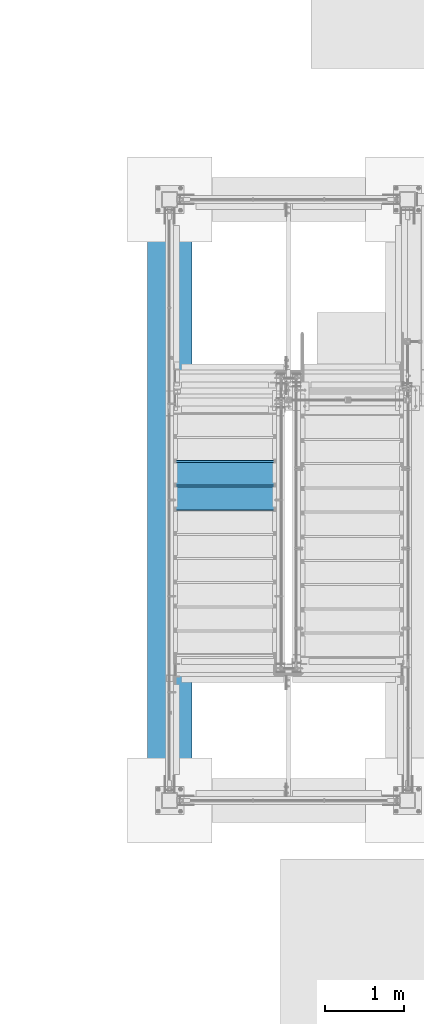
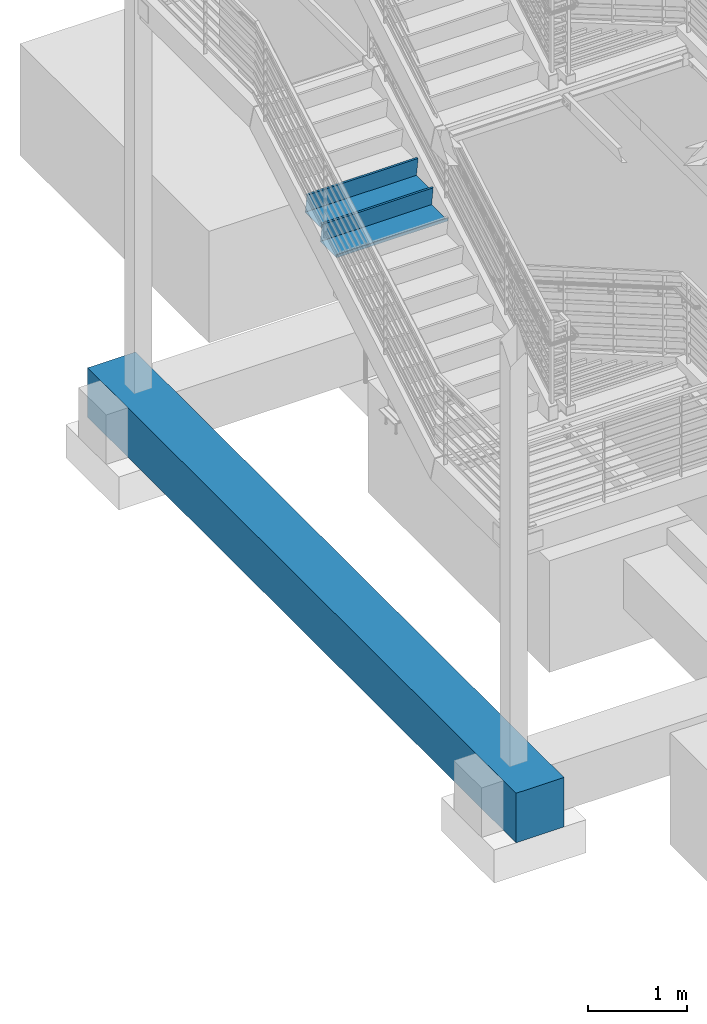
# One storey, part 757 of 1179: 3 beams, 2 elements without a shape of their own.
"""IFC2X3 building model written with IfcOpenShell, lengths in millimetres."""

from ifc_helpers import new_model, si_unit, frame, origin_with_axes, place, context, subcontext, project, spatial, faceted_brep, material, type_object, element, aggregate, save


model = new_model("IFC2X3")

# Units and contexts
model_context = context("Model", 3, precision=1e-05, world=origin_with_axes())
body_context = subcontext(model_context, "Body", "Model", "MODEL_VIEW")
ifc_project = project(units=[si_unit("LENGTHUNIT", "METRE", prefix="MILLI"), si_unit("AREAUNIT", "SQUARE_METRE"), si_unit("VOLUMEUNIT", "CUBIC_METRE"), si_unit("MASSUNIT", "GRAM", prefix="KILO"), si_unit("TIMEUNIT", "SECOND"), si_unit("PLANEANGLEUNIT", "RADIAN"), si_unit("SOLIDANGLEUNIT", "STERADIAN"), si_unit("THERMODYNAMICTEMPERATUREUNIT", "DEGREE_CELSIUS"), si_unit("LUMINOUSINTENSITYUNIT", "LUMEN")], contexts=[model_context])

# Site, building, storey
site_placement = place(None, origin_with_axes())
site = spatial("IfcSite", under=ifc_project, at=site_placement, CompositionType="ELEMENT")
building_placement = place(site_placement, origin_with_axes())
building = spatial("IfcBuilding", under=site, at=building_placement, Name="Undefined", CompositionType="ELEMENT")
storey_placement = place(building_placement, origin_with_axes())
storey = spatial("IfcBuildingStorey", under=building, at=storey_placement, Name="Undefined", CompositionType="ELEMENT", Elevation=0.0)

# Assembly, beams
assembly_1_placement = place(storey_placement, origin_with_axes())
assembly_1 = element("IfcElementAssembly", 1, at=assembly_1_placement, inside=storey, Name="STRINGER", AssemblyPlace="NOTDEFINED", PredefinedType="RIGID_FRAME")
ifc_material_1 = material(Name="STEEL/A36")
beam_type_1 = type_object("IfcBeamType", PredefinedType="NOTDEFINED")
beam_1_placement = place(assembly_1_placement, frame((-2552.70000000055, 34353.5000002913, 3704.43125000059), z_axis=(1.0, 0.0, 0.0), x_axis=(0.0, -1.0, 0.0)))
beam_1 = element("IfcBeam", 2, at=beam_1_placement, type_object=beam_type_1, material=ifc_material_1, Name="TREAD", context=body_context, shape_type="Brep", body=[
    faceted_brep([(-5.47515810467303e-10, -1.58750000000146, -647.7), (-5.47515810467303e-10, -1.58750000000146, 647.7), (5.49334799870849e-10, 1.58749999999418, 647.7), (5.49334799870849e-10, 1.58749999999418, -647.7), (21.7353257776667, 1.58750000000009, 647.7), (21.7353257776667, 1.58750000000009, -647.7), (25.4000000001688, -1.58750000000009, -647.7), (25.4000000001688, -1.58750000000009, 647.7), (-10.9762326817727, 228.864583333333, 647.7), (-10.9762326817727, 228.864583333333, -647.7), (-7.31154422789405, 225.689583333333, -647.7), (-7.31154422789405, 225.689583333333, 647.7), (319.223767229007, 228.864583333333, 647.7), (319.223767229007, 228.864583333333, -647.7), (316.473021803613, 225.689583333333, -647.7), (316.473021803613, 225.689583333333, 647.7), (325.043366447484, 188.430492929979, 647.7), (325.043366447484, 188.430492929979, -647.7), (321.900749692417, 187.978182272578, 647.7), (321.900749692417, 187.978182272578, -647.7)], [[[0, 1, 2, 3]], [[3, 2, 4, 5]], [[1, 0, 6, 7]], [[5, 4, 8, 9]], [[7, 6, 10, 11]], [[9, 8, 12, 13]], [[11, 10, 14, 15]], [[13, 12, 16, 17]], [[12, 8, 4, 2, 1, 7, 11, 15, 18, 16]], [[15, 14, 19, 18]], [[14, 10, 6, 0, 3, 5, 9, 13, 17, 19]], [[18, 19, 17, 16]]]),
])
beam_2_placement = place(assembly_1_placement, frame((-2552.70000000059, 34048.7000003805, 3527.95416666726), z_axis=(1.0, 0.0, 0.0), x_axis=(0.0, -1.0, 0.0)))
beam_2 = element("IfcBeam", 3, at=beam_2_placement, type_object=beam_type_1, material=ifc_material_1, Name="TREAD", context=body_context, shape_type="Brep", body=[
    faceted_brep([(-5.47515810467303e-10, -1.58750000000146, -647.7), (-5.47515810467303e-10, -1.58750000000146, 647.7), (5.49334799870849e-10, 1.58749999999418, 647.7), (5.49334799870849e-10, 1.58749999999418, -647.7), (21.7353257776667, 1.58750000000009, 647.7), (21.7353257776667, 1.58750000000009, -647.7), (25.4000000001688, -1.58750000000009, -647.7), (25.4000000001688, -1.58750000000009, 647.7), (-10.9762326817727, 228.864583333333, 647.7), (-10.9762326817727, 228.864583333333, -647.7), (-7.31154422789405, 225.689583333333, -647.7), (-7.31154422789405, 225.689583333333, 647.7), (319.223767229007, 228.864583333333, 647.7), (319.223767229007, 228.864583333333, -647.7), (316.473021803613, 225.689583333333, -647.7), (316.473021803613, 225.689583333333, 647.7), (325.043366447484, 188.430492929979, 647.7), (325.043366447484, 188.430492929979, -647.7), (321.900749692417, 187.978182272578, 647.7), (321.900749692417, 187.978182272578, -647.7)], [[[0, 1, 2, 3]], [[3, 2, 4, 5]], [[1, 0, 6, 7]], [[5, 4, 8, 9]], [[7, 6, 10, 11]], [[9, 8, 12, 13]], [[11, 10, 14, 15]], [[13, 12, 16, 17]], [[12, 8, 4, 2, 1, 7, 11, 15, 18, 16]], [[15, 14, 19, 18]], [[14, 10, 6, 0, 3, 5, 9, 13, 17, 19]], [[18, 19, 17, 16]]]),
])
aggregate(assembly_1, [beam_1, beam_2])

# Assembly, beam
assembly_2_placement = place(storey_placement, origin_with_axes())
assembly_2 = element("IfcElementAssembly", 4, at=assembly_2_placement, inside=storey, Name="GRADE_BEAM", AssemblyPlace="NOTDEFINED", PredefinedType="REINFORCEMENT_UNIT")
ifc_material_2 = material(Name="CONCRETE/5000")
beam_type_2 = type_object("IfcBeamType", PredefinedType="NOTDEFINED")
beam_3_placement = place(assembly_2_placement, frame((-3251.2, 29540.2, -939.8), z_axis=(0.0, 0.0, 1.0), x_axis=(0.0, 1.0, 0.0)))
beam_3 = element("IfcBeam", 5, at=beam_3_placement, type_object=beam_type_2, material=ifc_material_2, Name="GRADE_BEAM", context=body_context, shape_type="Brep", body=[
    faceted_brep([(0.0, 279.4, -304.8), (0.0, 279.4, 304.8), (8636.0, 279.4, 304.8), (8636.0, 279.4, -304.8), (0.0, -279.4, 304.8), (8636.0, -279.4, 304.8), (0.0, -279.4, -304.8), (8636.0, -279.4, -304.8)], [[[0, 1, 2, 3]], [[1, 4, 5, 2]], [[4, 6, 7, 5]], [[6, 0, 3, 7]], [[5, 7, 3, 2]], [[6, 4, 1, 0]]]),
])
aggregate(assembly_2, [beam_3])

save(model, "model.ifc")
